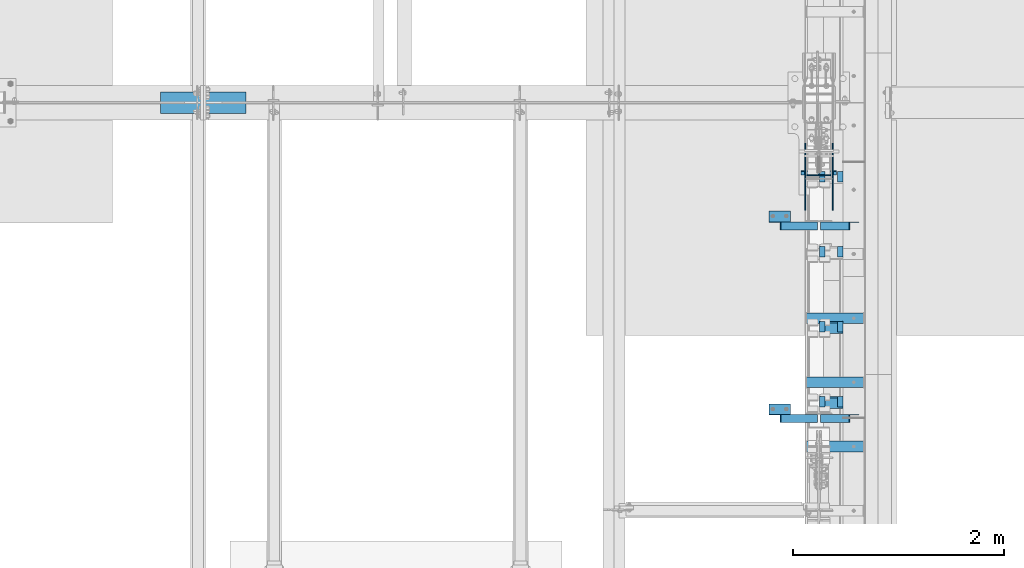
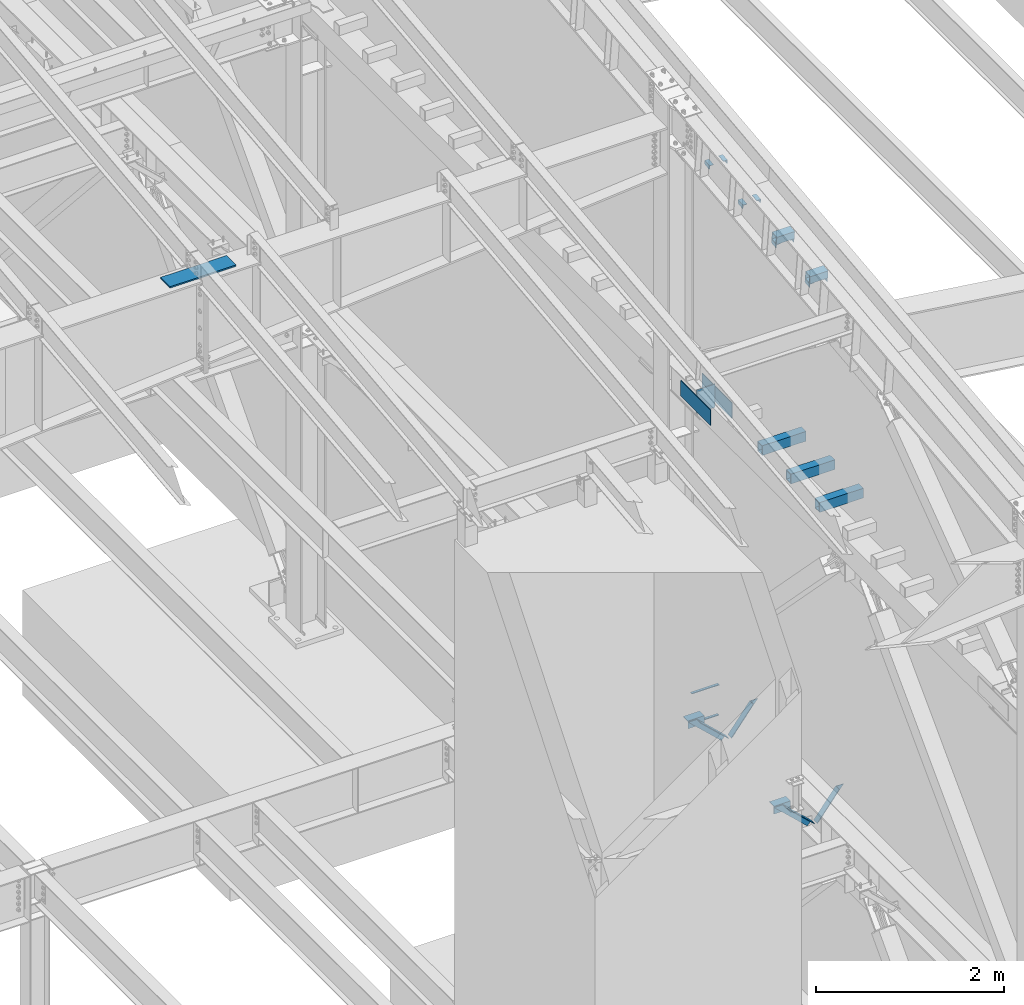
# One storey, part 837 of 1179: 21 beams, 4 members, 18 elements without a shape of their own.
"""IFC2X3 building model written with IfcOpenShell, lengths in millimetres."""

from ifc_helpers import new_model, si_unit, frame, origin_with_axes, place, context, subcontext, project, spatial, faceted_brep, material, type_object, element, aggregate, save


model = new_model("IFC2X3")

# Units and contexts
model_context = context("Model", 3, precision=1e-05, world=origin_with_axes())
body_context = subcontext(model_context, "Body", "Model", "MODEL_VIEW")
ifc_project = project(units=[si_unit("LENGTHUNIT", "METRE", prefix="MILLI"), si_unit("AREAUNIT", "SQUARE_METRE"), si_unit("VOLUMEUNIT", "CUBIC_METRE"), si_unit("MASSUNIT", "GRAM", prefix="KILO"), si_unit("TIMEUNIT", "SECOND"), si_unit("PLANEANGLEUNIT", "RADIAN"), si_unit("SOLIDANGLEUNIT", "STERADIAN"), si_unit("THERMODYNAMICTEMPERATUREUNIT", "DEGREE_CELSIUS"), si_unit("LUMINOUSINTENSITYUNIT", "LUMEN")], contexts=[model_context])

# Site, building, storey
site_placement = place(None, origin_with_axes())
site = spatial("IfcSite", under=ifc_project, at=site_placement, CompositionType="ELEMENT")
building_placement = place(site_placement, origin_with_axes())
building = spatial("IfcBuilding", under=site, at=building_placement, Name="Undefined", CompositionType="ELEMENT")
storey_placement = place(building_placement, origin_with_axes())
storey = spatial("IfcBuildingStorey", under=building, at=storey_placement, Name="Undefined", CompositionType="ELEMENT", Elevation=0.0)

# Assembly, member
assembly_1_placement = place(storey_placement, origin_with_axes())
assembly_1 = element("IfcElementAssembly", 1, at=assembly_1_placement, inside=storey, Name="ANGLE", AssemblyPlace="NOTDEFINED", PredefinedType="RIGID_FRAME")
ifc_material_1 = material(Name="STEEL/A36")
member_type = type_object("IfcMemberType", Name="L3X3X1/4", PredefinedType="NOTDEFINED")
member_1_placement = place(assembly_1_placement, frame((23812.1150890972, 18059.4, 4162.88757791506), z_axis=(0.0, -1.0, 0.0), x_axis=(0.729484494811633, 0.0, -0.683997347823379)))
member_1 = element("IfcMember", 2, at=member_1_placement, type_object=member_type, material=ifc_material_1, Name="ANGLE", ObjectType="L3X3X1/4", context=body_context, shape_type="Brep", body=[
    faceted_brep([(148.072119708857, 38.1000000000204, -38.0999999999985), (148.072119708857, 38.1000000000204, 38.0999999999985), (623.824460863128, 38.1000000000349, 38.0999999999985), (623.824460863128, 38.1000000000349, -38.0999999999985), (141.299832423247, 31.7500000000182, 38.0999999999985), (623.824460863128, 31.7500000000291, 38.0999999999985), (141.299832423247, 31.7500000000182, -31.75), (623.824460863128, 31.7500000000291, -31.75), (66.8046722815307, -38.1000000000095, -31.75), (623.824460863132, -38.0999999999913, -31.75), (66.8046722815307, -38.1000000000095, -38.0999999999985), (623.824460863132, -38.0999999999913, -38.0999999999985)], [[[0, 1, 2, 3]], [[1, 4, 5, 2]], [[4, 6, 7, 5]], [[6, 8, 9, 7]], [[8, 10, 11, 9]], [[10, 0, 3, 11]], [[5, 7, 9, 11, 3, 2]], [[10, 8, 6, 4, 1, 0]]]),
])
aggregate(assembly_1, [member_1])

assembly_2_placement = place(storey_placement, origin_with_axes())
assembly_2 = element("IfcElementAssembly", 3, at=assembly_2_placement, inside=storey, Name="ANGLE", AssemblyPlace="NOTDEFINED", PredefinedType="RIGID_FRAME")
member_2_placement = place(assembly_2_placement, frame((24352.3014298031, 18059.4, 3731.6636484264), z_axis=(0.0, -1.0, 0.0), x_axis=(0.614083067285056, 0.0, 0.789241399366365)))
member_2 = element("IfcMember", 4, at=member_2_placement, type_object=member_type, material=ifc_material_1, Name="ANGLE", ObjectType="L3X3X1/4", context=body_context, shape_type="Brep", body=[
    faceted_brep([(0.0, 38.0999999999985, -38.0999999999999), (0.0, 38.0999999999985, 38.0999999999999), (439.713105507173, 38.1000000000386, 38.0999999999985), (439.713105507173, 38.1000000000386, -38.0999999999985), (0.0, 31.75, 38.1000000000004), (444.653834009747, 31.7500000000473, 38.0999999999985), (0.0, 31.75, -31.75), (444.653834009747, 31.7500000000473, -31.75), (0.0, -38.0999999999985, -31.75), (499.001847538042, -38.0999999998749, -31.75), (0.0, -38.0999999999985, -38.0999999999999), (499.001847538042, -38.0999999998749, -38.0999999999985)], [[[0, 1, 2, 3]], [[1, 4, 5, 2]], [[4, 6, 7, 5]], [[6, 8, 9, 7]], [[8, 10, 11, 9]], [[10, 0, 3, 11]], [[5, 7, 9, 11, 3, 2]], [[10, 8, 6, 4, 1, 0]]]),
])
aggregate(assembly_2, [member_2])

assembly_3_placement = place(storey_placement, origin_with_axes())
assembly_3 = element("IfcElementAssembly", 5, at=assembly_3_placement, inside=storey, Name="ANGLE", AssemblyPlace="NOTDEFINED", PredefinedType="RIGID_FRAME")
member_3_placement = place(assembly_3_placement, frame((23812.1150890972, 16230.6, 4162.88757791506), z_axis=(0.0, -1.0, 0.0), x_axis=(0.729484494811633, 0.0, -0.683997347823379)))
member_3 = element("IfcMember", 6, at=member_3_placement, type_object=member_type, material=ifc_material_1, Name="ANGLE", ObjectType="L3X3X1/4", context=body_context, shape_type="Brep", body=[
    faceted_brep([(148.072119708857, 38.1000000000204, -38.0999999999985), (148.072119708857, 38.1000000000204, 38.0999999999985), (623.824460863128, 38.1000000000349, 38.0999999999985), (623.824460863128, 38.1000000000349, -38.0999999999985), (141.299832423247, 31.7500000000182, 38.0999999999985), (623.824460863128, 31.7500000000291, 38.0999999999985), (141.299832423247, 31.7500000000182, -31.75), (623.824460863128, 31.7500000000291, -31.75), (66.8046722815307, -38.1000000000095, -31.75), (623.824460863132, -38.0999999999913, -31.75), (66.8046722815307, -38.1000000000095, -38.0999999999985), (623.824460863132, -38.0999999999913, -38.0999999999985)], [[[0, 1, 2, 3]], [[1, 4, 5, 2]], [[4, 6, 7, 5]], [[6, 8, 9, 7]], [[8, 10, 11, 9]], [[10, 0, 3, 11]], [[5, 7, 9, 11, 3, 2]], [[10, 8, 6, 4, 1, 0]]]),
])
aggregate(assembly_3, [member_3])

assembly_4_placement = place(storey_placement, origin_with_axes())
assembly_4 = element("IfcElementAssembly", 7, at=assembly_4_placement, inside=storey, Name="ANGLE", AssemblyPlace="NOTDEFINED", PredefinedType="RIGID_FRAME")
member_4_placement = place(assembly_4_placement, frame((24352.3014298031, 16230.6, 3731.6636484264), z_axis=(0.0, -1.0, 0.0), x_axis=(0.614083067285056, 0.0, 0.789241399366365)))
member_4 = element("IfcMember", 8, at=member_4_placement, type_object=member_type, material=ifc_material_1, Name="ANGLE", ObjectType="L3X3X1/4", context=body_context, shape_type="Brep", body=[
    faceted_brep([(0.0, 38.0999999999985, -38.0999999999999), (0.0, 38.0999999999985, 38.0999999999999), (439.713105507173, 38.1000000000386, 38.0999999999985), (439.713105507173, 38.1000000000386, -38.0999999999985), (0.0, 31.75, 38.1000000000004), (444.653834009747, 31.7500000000473, 38.0999999999985), (0.0, 31.75, -31.75), (444.653834009747, 31.7500000000473, -31.75), (0.0, -38.0999999999985, -31.75), (499.001847538042, -38.0999999998749, -31.75), (0.0, -38.0999999999985, -38.0999999999999), (499.001847538042, -38.0999999998749, -38.0999999999985)], [[[0, 1, 2, 3]], [[1, 4, 5, 2]], [[4, 6, 7, 5]], [[6, 8, 9, 7]], [[8, 10, 11, 9]], [[10, 0, 3, 11]], [[5, 7, 9, 11, 3, 2]], [[10, 8, 6, 4, 1, 0]]]),
])
aggregate(assembly_4, [member_4])

# Assembly, beams
assembly_5_placement = place(storey_placement, origin_with_axes())
assembly_5 = element("IfcElementAssembly", 9, at=assembly_5_placement, inside=storey, Name="BEAM", AssemblyPlace="NOTDEFINED", PredefinedType="RIGID_FRAME")
ifc_material_2 = material(Name="STEEL/A572-GR.50")
beam_type_1 = type_object("IfcBeamType", PredefinedType="NOTDEFINED")
beam_1_placement = place(assembly_5_placement, frame((24307.8000366209, 18586.1140696771, 3678.2375), z_axis=(-1.0, 0.0, 0.0), x_axis=(0.0, -1.0, 0.0)))
beam_1 = element("IfcBeam", 10, at=beam_1_placement, type_object=beam_type_1, material=ifc_material_2, Name="PLATE", context=body_context, shape_type="Brep", body=[
    faceted_brep([(0.0, 4.76249999999982, -168.275000000001), (0.0, 4.76250000000073, 168.275), (31.75, 4.76249999999982, 168.275000000001), (31.75, 4.76249999999982, -168.275000000001), (0.0, -4.76250000000073, 168.275), (31.75, -4.76249999999982, 168.275000000001), (0.0, -4.76249999999982, -168.275000000001), (31.75, -4.76249999999982, -168.275000000001)], [[[0, 1, 2, 3]], [[1, 4, 5, 2]], [[4, 6, 7, 5]], [[6, 0, 3, 7]], [[5, 7, 3, 2]], [[6, 4, 1, 0]]]),
])
beam_2_placement = place(assembly_5_placement, frame((24307.8000366209, 18575.0015696771, 4077.8905), z_axis=(-1.0, 0.0, 0.0), x_axis=(0.0, -1.0, 0.0)))
beam_2 = element("IfcBeam", 11, at=beam_2_placement, type_object=beam_type_1, material=ifc_material_2, Name="PLATE", context=body_context, shape_type="Brep", body=[
    faceted_brep([(0.0, 4.76249999999982, -168.275000000001), (0.0, 4.76250000000073, 168.275), (31.75, 4.76249999999982, 168.275000000001), (31.75, 4.76249999999982, -168.275000000001), (0.0, -4.76250000000073, 168.275), (31.75, -4.76249999999982, 168.275000000001), (0.0, -4.76249999999982, -168.275000000001), (31.75, -4.76249999999982, -168.275000000001)], [[[0, 1, 2, 3]], [[1, 4, 5, 2]], [[4, 6, 7, 5]], [[6, 0, 3, 7]], [[5, 7, 3, 2]], [[6, 4, 1, 0]]]),
])
aggregate(assembly_5, [beam_1, beam_2])

# Assembly, beam
assembly_6_placement = place(storey_placement, origin_with_axes())
assembly_6 = element("IfcElementAssembly", 12, at=assembly_6_placement, inside=storey, Name="BEAM", AssemblyPlace="NOTDEFINED", PredefinedType="RIGID_FRAME")
beam_type_2 = type_object("IfcBeamType", Name="L2X2X1/4", PredefinedType="NOTDEFINED")
beam_3_placement = place(assembly_6_placement, frame((24511.0, 18475.6429543655, 10899.1275416578), z_axis=(0.0, 0.112284087038014, -0.993676146336441), x_axis=(0.0, 0.993676146336441, 0.112284087038017)))
beam_3 = element("IfcBeam", 13, at=beam_3_placement, type_object=beam_type_2, material=ifc_material_1, Name="ANGLE", ObjectType="L2X2X1/4", context=body_context, shape_type="Brep", body=[
    faceted_brep([(0.0, 25.3999999999996, -25.4000000000015), (0.0, 25.3999999999996, 25.4000000000015), (101.599999999555, 25.4, 25.3999999999451), (101.599999999537, 25.4, -25.4000000000251), (7.27595761418343e-12, 19.05, 25.3999999999851), (101.599999999555, 19.05, 25.3999999999451), (0.0, 19.0499992350015, -19.0499992349996), (101.600003324515, 19.0499992350051, -19.0499992350015), (-1.09139364212751e-11, -25.4, -19.0499999999865), (101.59999999954, -25.4, -19.0500000000302), (0.0, -25.3999999999996, -25.4000000000015), (101.599999999537, -25.4, -25.4000000000251)], [[[0, 1, 2, 3]], [[1, 4, 5, 2]], [[4, 6, 7, 5]], [[6, 8, 9, 7]], [[8, 10, 11, 9]], [[10, 0, 3, 11]], [[5, 7, 9, 11, 3, 2]], [[10, 8, 6, 4, 1, 0]]]),
])

assembly_7_placement = place(storey_placement, origin_with_axes())
assembly_7 = element("IfcElementAssembly", 14, at=assembly_7_placement, inside=storey, Name="BEAM", AssemblyPlace="NOTDEFINED", PredefinedType="RIGID_FRAME")
beam_4_placement = place(assembly_7_placement, frame((24340.34375, 18475.6429543655, 10899.1275416578), z_axis=(1.0, 0.0, 0.0), x_axis=(0.0, 0.993676146336441, 0.112284087038017)))
beam_4 = element("IfcBeam", 15, at=beam_4_placement, type_object=beam_type_2, material=ifc_material_1, Name="ANGLE", ObjectType="L2X2X1/4", context=body_context, shape_type="Brep", body=[
    faceted_brep([(0.0, 25.3999999999996, -25.4000000000015), (0.0, 25.3999999999996, 25.4000000000015), (101.599999999555, 25.4, 25.3999999999451), (101.599999999537, 25.4, -25.4000000000251), (7.27595761418343e-12, 19.05, 25.3999999999851), (101.599999999555, 19.05, 25.3999999999451), (0.0, 19.0499992350015, -19.0499992349996), (101.600003324515, 19.0499992350051, -19.0499992350015), (-1.09139364212751e-11, -25.4, -19.0499999999865), (101.59999999954, -25.4, -19.0500000000302), (0.0, -25.3999999999996, -25.4000000000015), (101.599999999537, -25.4, -25.4000000000251)], [[[0, 1, 2, 3]], [[1, 4, 5, 2]], [[4, 6, 7, 5]], [[6, 8, 9, 7]], [[8, 10, 11, 9]], [[10, 0, 3, 11]], [[5, 7, 9, 11, 3, 2]], [[10, 8, 6, 4, 1, 0]]]),
])

# Beam
beam_5_placement = place(assembly_6_placement, frame((24511.0, 17764.0119919854, 10818.6588636447), z_axis=(0.0, 0.112284087038014, -0.993676146336441), x_axis=(0.0, 0.993676146336441, 0.112284087038017)))
beam_5 = element("IfcBeam", 16, at=beam_5_placement, type_object=beam_type_2, material=ifc_material_1, Name="ANGLE", ObjectType="L2X2X1/4", context=body_context, shape_type="Brep", body=[
    faceted_brep([(0.0, 25.3999999999996, -25.4000000000015), (0.0, 25.3999999999996, 25.4000000000015), (101.599999999555, 25.4, 25.3999999999451), (101.599999999537, 25.4, -25.4000000000251), (7.27595761418343e-12, 19.05, 25.3999999999851), (101.599999999555, 19.05, 25.3999999999451), (0.0, 19.0499992350015, -19.0499992349996), (101.600003324515, 19.0499992350051, -19.0499992350015), (-1.09139364212751e-11, -25.4, -19.0499999999865), (101.59999999954, -25.4, -19.0500000000302), (0.0, -25.3999999999996, -25.4000000000015), (101.599999999537, -25.4, -25.4000000000251)], [[[0, 1, 2, 3]], [[1, 4, 5, 2]], [[4, 6, 7, 5]], [[6, 8, 9, 7]], [[8, 10, 11, 9]], [[10, 0, 3, 11]], [[5, 7, 9, 11, 3, 2]], [[10, 8, 6, 4, 1, 0]]]),
])

beam_6_placement = place(assembly_7_placement, frame((24340.34375, 17764.0119919854, 10818.6588636447), z_axis=(1.0, 0.0, 0.0), x_axis=(0.0, 0.993676146336441, 0.112284087038017)))
beam_6 = element("IfcBeam", 17, at=beam_6_placement, type_object=beam_type_2, material=ifc_material_1, Name="ANGLE", ObjectType="L2X2X1/4", context=body_context, shape_type="Brep", body=[
    faceted_brep([(0.0, 25.3999999999996, -25.4000000000015), (0.0, 25.3999999999996, 25.4000000000015), (101.599999999555, 25.4, 25.3999999999451), (101.599999999537, 25.4, -25.4000000000251), (7.27595761418343e-12, 19.05, 25.3999999999851), (101.599999999555, 19.05, 25.3999999999451), (0.0, 19.0499992350015, -19.0499992349996), (101.600003324515, 19.0499992350051, -19.0499992350015), (-1.09139364212751e-11, -25.4, -19.0499999999865), (101.59999999954, -25.4, -19.0500000000302), (0.0, -25.3999999999996, -25.4000000000015), (101.599999999537, -25.4, -25.4000000000251)], [[[0, 1, 2, 3]], [[1, 4, 5, 2]], [[4, 6, 7, 5]], [[6, 8, 9, 7]], [[8, 10, 11, 9]], [[10, 0, 3, 11]], [[5, 7, 9, 11, 3, 2]], [[10, 8, 6, 4, 1, 0]]]),
])

beam_7_placement = place(assembly_6_placement, frame((24511.0, 17052.3810296053, 10738.1901856316), z_axis=(0.0, 0.112284087038014, -0.993676146336441), x_axis=(0.0, 0.993676146336441, 0.112284087038017)))
beam_7 = element("IfcBeam", 18, at=beam_7_placement, type_object=beam_type_2, material=ifc_material_1, Name="ANGLE", ObjectType="L2X2X1/4", context=body_context, shape_type="Brep", body=[
    faceted_brep([(0.0, 25.3999999999996, -25.4000000000015), (0.0, 25.3999999999996, 25.4000000000015), (101.599999999555, 25.4, 25.3999999999451), (101.599999999537, 25.4, -25.4000000000251), (7.27595761418343e-12, 19.05, 25.3999999999851), (101.599999999555, 19.05, 25.3999999999451), (0.0, 19.0499992350015, -19.0499992349996), (101.600003324515, 19.0499992350051, -19.0499992350015), (-1.09139364212751e-11, -25.4, -19.0499999999865), (101.59999999954, -25.4, -19.0500000000302), (0.0, -25.3999999999996, -25.4000000000015), (101.599999999537, -25.4, -25.4000000000251)], [[[0, 1, 2, 3]], [[1, 4, 5, 2]], [[4, 6, 7, 5]], [[6, 8, 9, 7]], [[8, 10, 11, 9]], [[10, 0, 3, 11]], [[5, 7, 9, 11, 3, 2]], [[10, 8, 6, 4, 1, 0]]]),
])

beam_8_placement = place(assembly_7_placement, frame((24340.34375, 17052.3810296052, 10738.1901856316), z_axis=(1.0, 0.0, 0.0), x_axis=(0.0, 0.993676146336441, 0.112284087038017)))
beam_8 = element("IfcBeam", 19, at=beam_8_placement, type_object=beam_type_2, material=ifc_material_1, Name="ANGLE", ObjectType="L2X2X1/4", context=body_context, shape_type="Brep", body=[
    faceted_brep([(0.0, 25.3999999999996, -25.4000000000015), (0.0, 25.3999999999996, 25.4000000000015), (101.599999999555, 25.4, 25.3999999999451), (101.599999999537, 25.4, -25.4000000000251), (7.27595761418343e-12, 19.05, 25.3999999999851), (101.599999999555, 19.05, 25.3999999999451), (0.0, 19.0499992350015, -19.0499992349996), (101.600003324515, 19.0499992350051, -19.0499992350015), (-1.09139364212751e-11, -25.4, -19.0499999999865), (101.59999999954, -25.4, -19.0500000000302), (0.0, -25.3999999999996, -25.4000000000015), (101.599999999537, -25.4, -25.4000000000251)], [[[0, 1, 2, 3]], [[1, 4, 5, 2]], [[4, 6, 7, 5]], [[6, 8, 9, 7]], [[8, 10, 11, 9]], [[10, 0, 3, 11]], [[5, 7, 9, 11, 3, 2]], [[10, 8, 6, 4, 1, 0]]]),
])

beam_9_placement = place(assembly_6_placement, frame((24511.0, 16340.7500672251, 10657.7215076184), z_axis=(0.0, 0.112284087038014, -0.993676146336441), x_axis=(0.0, 0.993676146336441, 0.112284087038017)))
beam_9 = element("IfcBeam", 20, at=beam_9_placement, type_object=beam_type_2, material=ifc_material_1, Name="ANGLE", ObjectType="L2X2X1/4", context=body_context, shape_type="Brep", body=[
    faceted_brep([(0.0, 25.3999999999996, -25.4000000000015), (0.0, 25.3999999999996, 25.4000000000015), (101.599999999555, 25.4, 25.3999999999451), (101.599999999537, 25.4, -25.4000000000251), (7.27595761418343e-12, 19.05, 25.3999999999851), (101.599999999555, 19.05, 25.3999999999451), (0.0, 19.0499992350015, -19.0499992349996), (101.600003324515, 19.0499992350051, -19.0499992350015), (-1.09139364212751e-11, -25.4, -19.0499999999865), (101.59999999954, -25.4, -19.0500000000302), (0.0, -25.3999999999996, -25.4000000000015), (101.599999999537, -25.4, -25.4000000000251)], [[[0, 1, 2, 3]], [[1, 4, 5, 2]], [[4, 6, 7, 5]], [[6, 8, 9, 7]], [[8, 10, 11, 9]], [[10, 0, 3, 11]], [[5, 7, 9, 11, 3, 2]], [[10, 8, 6, 4, 1, 0]]]),
])

aggregate(assembly_6, [beam_3, beam_5, beam_7, beam_9])

beam_10_placement = place(assembly_7_placement, frame((24340.34375, 16340.7500672251, 10657.7215076184), z_axis=(1.0, 0.0, 0.0), x_axis=(0.0, 0.993676146336441, 0.112284087038017)))
beam_10 = element("IfcBeam", 21, at=beam_10_placement, type_object=beam_type_2, material=ifc_material_1, Name="ANGLE", ObjectType="L2X2X1/4", context=body_context, shape_type="Brep", body=[
    faceted_brep([(0.0, 25.3999999999996, -25.4000000000015), (0.0, 25.3999999999996, 25.4000000000015), (101.599999999555, 25.4, 25.3999999999451), (101.599999999537, 25.4, -25.4000000000251), (7.27595761418343e-12, 19.05, 25.3999999999851), (101.599999999555, 19.05, 25.3999999999451), (0.0, 19.0499992350015, -19.0499992349996), (101.600003324515, 19.0499992350051, -19.0499992350015), (-1.09139364212751e-11, -25.4, -19.0499999999865), (101.59999999954, -25.4, -19.0500000000302), (0.0, -25.3999999999996, -25.4000000000015), (101.599999999537, -25.4, -25.4000000000251)], [[[0, 1, 2, 3]], [[1, 4, 5, 2]], [[4, 6, 7, 5]], [[6, 8, 9, 7]], [[8, 10, 11, 9]], [[10, 0, 3, 11]], [[5, 7, 9, 11, 3, 2]], [[10, 8, 6, 4, 1, 0]]]),
])

aggregate(assembly_7, [beam_4, beam_6, beam_8, beam_10])

# Assembly, beam
assembly_8_placement = place(storey_placement, origin_with_axes())
assembly_8 = element("IfcElementAssembly", 22, at=assembly_8_placement, inside=storey, Name="RAFTER BEAM", AssemblyPlace="NOTDEFINED", PredefinedType="RIGID_FRAME")
beam_type_3 = type_object("IfcBeamType", PredefinedType="NOTDEFINED")
beam_11_placement = place(assembly_8_placement, frame((18059.4, 19227.8, 11137.10625), z_axis=(0.0, -1.0, 0.0), x_axis=(1.0, 0.0, 0.0)))
beam_11 = element("IfcBeam", 23, at=beam_11_placement, type_object=beam_type_3, material=ifc_material_2, Name="PLATE", context=body_context, shape_type="Brep", body=[
    faceted_brep([(0.0, 9.52500000000009, -101.599999999999), (0.0, 9.52500000000009, 101.599999999999), (812.799999999999, 9.52499999999964, 101.6), (812.799999999999, 9.52499999999964, -101.6), (0.0, -9.52500000000009, 101.599999999999), (812.799999999999, -9.52499999999964, 101.6), (0.0, -9.52500000000009, -101.599999999999), (812.799999999999, -9.52499999999964, -101.6)], [[[0, 1, 2, 3]], [[1, 4, 5, 2]], [[4, 6, 7, 5]], [[6, 0, 3, 7]], [[5, 7, 3, 2]], [[6, 4, 1, 0]]]),
])
aggregate(assembly_8, [beam_11])

assembly_9_placement = place(storey_placement, origin_with_axes())
assembly_9 = element("IfcElementAssembly", 24, at=assembly_9_placement, inside=storey, Name="ANGLE", AssemblyPlace="NOTDEFINED", PredefinedType="RIGID_FRAME")
beam_type_4 = type_object("IfcBeamType", Name="L4X4X1/4", PredefinedType="NOTDEFINED")
beam_12_placement = place(assembly_9_placement, frame((23834.8036446584, 18148.3, 4051.3), z_axis=(0.0, 0.0, -1.0), x_axis=(1.0, 0.0, 0.0)))
beam_12 = element("IfcBeam", 25, at=beam_12_placement, type_object=beam_type_4, material=ifc_material_1, Name="ANGLE", ObjectType="L4X4X1/4", context=body_context, shape_type="Brep", body=[
    faceted_brep([(1.90993887372315e-11, 50.8000000000002, -50.8000000000002), (1.90993887372315e-11, 50.8000000000002, 50.8000000000002), (203.200000000001, 50.7999999999993, 50.8000000000002), (203.200000000001, 50.7999999999993, -50.8000000000002), (0.0, 44.4500000000007, 50.8000000000002), (203.200000000001, 44.4500000000007, 50.8000000000002), (0.0, 44.4500000000007, -44.4499999999998), (203.200000000001, 44.4500000000007, -44.4499999999998), (0.0, -50.7999999999993, -44.4499999999998), (203.200000000001, -50.7999999999993, -44.4499999999998), (-1.81898940354586e-11, -50.7999999999997, -50.8000000000002), (203.200000000001, -50.7999999999993, -50.8000000000002)], [[[0, 1, 2, 3]], [[1, 4, 5, 2]], [[4, 6, 7, 5]], [[6, 8, 9, 7]], [[8, 10, 11, 9]], [[10, 0, 3, 11]], [[5, 7, 9, 11, 3, 2]], [[10, 8, 6, 4, 1, 0]]]),
])
aggregate(assembly_9, [beam_12])

assembly_10_placement = place(storey_placement, origin_with_axes())
assembly_10 = element("IfcElementAssembly", 26, at=assembly_10_placement, inside=storey, Name="ANGLE", AssemblyPlace="NOTDEFINED", PredefinedType="RIGID_FRAME")
beam_13_placement = place(assembly_10_placement, frame((23834.8036446584, 16319.5, 4051.3), z_axis=(0.0, 0.0, -1.0), x_axis=(1.0, 0.0, 0.0)))
beam_13 = element("IfcBeam", 27, at=beam_13_placement, type_object=beam_type_4, material=ifc_material_1, Name="ANGLE", ObjectType="L4X4X1/4", context=body_context, shape_type="Brep", body=[
    faceted_brep([(1.90993887372315e-11, 50.8000000000002, -50.8000000000002), (1.90993887372315e-11, 50.8000000000002, 50.8000000000002), (203.200000000001, 50.7999999999993, 50.8000000000002), (203.200000000001, 50.7999999999993, -50.8000000000002), (0.0, 44.4500000000007, 50.8000000000002), (203.200000000001, 44.4500000000007, 50.8000000000002), (0.0, 44.4500000000007, -44.4499999999998), (203.200000000001, 44.4500000000007, -44.4499999999998), (0.0, -50.7999999999993, -44.4499999999998), (203.200000000001, -50.7999999999993, -44.4499999999998), (-1.81898940354586e-11, -50.7999999999997, -50.8000000000002), (203.200000000001, -50.7999999999993, -50.8000000000002)], [[[0, 1, 2, 3]], [[1, 4, 5, 2]], [[4, 6, 7, 5]], [[6, 8, 9, 7]], [[8, 10, 11, 9]], [[10, 0, 3, 11]], [[5, 7, 9, 11, 3, 2]], [[10, 8, 6, 4, 1, 0]]]),
])
aggregate(assembly_10, [beam_13])

assembly_11_placement = place(storey_placement, origin_with_axes())
assembly_11 = element("IfcElementAssembly", 28, at=assembly_11_placement, inside=storey, Name="PLATE", AssemblyPlace="NOTDEFINED", PredefinedType="RIGID_FRAME")
beam_type_5 = type_object("IfcBeamType", PredefinedType="NOTDEFINED")
beam_14_placement = place(assembly_11_placement, frame((24439.5625, 18840.6248035139, 7861.3), z_axis=(0.0, 0.0, 1.0), x_axis=(0.0, -1.0, 0.0)))
beam_14 = element("IfcBeam", 29, at=beam_14_placement, type_object=beam_type_5, material=ifc_material_2, Name="PLATE", context=body_context, shape_type="Brep", body=[
    faceted_brep([(0.0, 4.76250000000073, -101.6), (0.0, 4.76250000000073, 101.6), (635.0, 4.76250000000073, 101.6), (635.0, 4.76250000000073, -101.6), (0.0, -4.76250000000073, 101.6), (635.0, -4.76250000000073, 101.6), (0.0, -4.76250000000073, -101.6), (635.0, -4.76250000000073, -101.6)], [[[0, 1, 2, 3]], [[1, 4, 5, 2]], [[4, 6, 7, 5]], [[6, 0, 3, 7]], [[5, 7, 3, 2]], [[6, 4, 1, 0]]]),
])
aggregate(assembly_11, [beam_14])

assembly_12_placement = place(storey_placement, origin_with_axes())
assembly_12 = element("IfcElementAssembly", 30, at=assembly_12_placement, inside=storey, Name="PLATE", AssemblyPlace="NOTDEFINED", PredefinedType="RIGID_FRAME")
beam_15_placement = place(assembly_12_placement, frame((24176.0375, 18840.6248035139, 7861.3), z_axis=(0.0, 0.0, 1.0), x_axis=(0.0, -1.0, 0.0)))
beam_15 = element("IfcBeam", 31, at=beam_15_placement, type_object=beam_type_5, material=ifc_material_2, Name="PLATE", context=body_context, shape_type="Brep", body=[
    faceted_brep([(0.0, 4.76250000000073, -101.6), (0.0, 4.76250000000073, 101.6), (635.0, 4.76250000000073, 101.6), (635.0, 4.76250000000073, -101.6), (0.0, -4.76250000000073, 101.6), (635.0, -4.76250000000073, 101.6), (0.0, -4.76250000000073, -101.6), (635.0, -4.76250000000073, -101.6)], [[[0, 1, 2, 3]], [[1, 4, 5, 2]], [[4, 6, 7, 5]], [[6, 0, 3, 7]], [[5, 7, 3, 2]], [[6, 4, 1, 0]]]),
])
aggregate(assembly_12, [beam_15])

assembly_13_placement = place(storey_placement, origin_with_axes())
assembly_13 = element("IfcElementAssembly", 32, at=assembly_13_placement, inside=storey, Name="COLUMN", AssemblyPlace="NOTDEFINED", PredefinedType="RIGID_FRAME")
beam_type_6 = type_object("IfcBeamType", PredefinedType="NOTDEFINED")
beam_16_placement = place(assembly_13_placement, frame((24193.5, 18540.5873035139, 7861.3), z_axis=(0.0, 0.0, 1.0), x_axis=(1.0, 0.0, 0.0)))
beam_16 = element("IfcBeam", 33, at=beam_16_placement, type_object=beam_type_6, material=ifc_material_2, Name="PLATE", context=body_context, shape_type="Brep", body=[
    faceted_brep([(0.0, 4.76250000000073, -152.4), (0.0, 4.76250000000073, 152.4), (228.600000000002, 4.76250000000073, 152.4), (228.600000000002, 4.76250000000073, -152.4), (0.0, -4.76250000000073, 152.4), (228.600000000002, -4.76250000000073, 152.4), (0.0, -4.76250000000073, -152.4), (228.600000000002, -4.76250000000073, -152.4)], [[[0, 1, 2, 3]], [[1, 4, 5, 2]], [[4, 6, 7, 5]], [[6, 0, 3, 7]], [[5, 7, 3, 2]], [[6, 4, 1, 0]]]),
])
aggregate(assembly_13, [beam_16])

assembly_14_placement = place(storey_placement, origin_with_axes())
assembly_14 = element("IfcElementAssembly", 34, at=assembly_14_placement, inside=storey, Name="BEAM", AssemblyPlace="NOTDEFINED", PredefinedType="RIGID_FRAME")
ifc_material_3 = material()
beam_type_7 = type_object("IfcBeamType", Name="HSS4X4X5/16", PredefinedType="NOTDEFINED")
beam_17_placement = place(assembly_14_placement, frame((24307.8, 17094.3037304068, 10819.6123396039), z_axis=(0.0, -0.112284087038017, 0.993676146336441), x_axis=(1.0, 0.0, 0.0)))
beam_17 = element("IfcBeam", 35, at=beam_17_placement, type_object=beam_type_7, material=ifc_material_3, Name="BEAM", ObjectType="HSS4X4X5/16", context=body_context, shape_type="Brep", body=[
    faceted_brep([(7.14374999999757, 42.8624999999884, -42.8624999999574), (7.14374999999757, -42.8624999999593, -42.862499999992), (228.600000000002, -42.8624999999593, -42.862499999992), (228.600000000002, 42.8624999999884, -42.8624999999574), (7.14374999999757, -42.8624999999956, 42.8624999999611), (228.600000000002, -42.8624999999956, 42.8624999999611), (7.14374999999757, 42.862499999952, 42.8624999999938), (228.600000000002, 42.862499999952, 42.8624999999938), (7.14374999999757, 50.7999999999884, -50.7999999999502), (7.14374999999757, 50.7999999999447, 50.7999999999938), (228.600000000002, 50.7999999999447, 50.7999999999938), (228.600000000002, 50.7999999999884, -50.7999999999502), (7.14374999999757, -50.7999999999956, 50.799999999952), (228.600000000002, -50.7999999999956, 50.799999999952), (7.14374999999757, -50.7999999999556, -50.7999999999902), (228.600000000002, -50.7999999999556, -50.7999999999902)], [[[0, 1, 2, 3]], [[1, 4, 5, 2]], [[4, 6, 7, 5]], [[6, 0, 3, 7]], [[8, 9, 10, 11]], [[9, 12, 13, 10]], [[12, 14, 15, 13]], [[14, 8, 11, 15]], [[13, 15, 11, 10], [5, 7, 3, 2]], [[14, 12, 9, 8], [6, 4, 1, 0]]]),
])
aggregate(assembly_14, [beam_17])

assembly_15_placement = place(storey_placement, origin_with_axes())
assembly_15 = element("IfcElementAssembly", 36, at=assembly_15_placement, inside=storey, Name="BEAM", AssemblyPlace="NOTDEFINED", PredefinedType="RIGID_FRAME")
beam_18_placement = place(assembly_15_placement, frame((24307.8, 16382.6727680267, 10739.1436615907), z_axis=(0.0, -0.112284087038017, 0.993676146336441), x_axis=(1.0, 0.0, 0.0)))
beam_18 = element("IfcBeam", 37, at=beam_18_placement, type_object=beam_type_7, material=ifc_material_3, Name="BEAM", ObjectType="HSS4X4X5/16", context=body_context, shape_type="Brep", body=[
    faceted_brep([(7.14374999999757, 42.8624999999884, -42.8624999999574), (7.14374999999757, -42.8624999999593, -42.862499999992), (228.600000000002, -42.8624999999593, -42.862499999992), (228.600000000002, 42.8624999999884, -42.8624999999574), (7.14374999999757, -42.8624999999956, 42.8624999999611), (228.600000000002, -42.8624999999956, 42.8624999999611), (7.14374999999757, 42.862499999952, 42.8624999999938), (228.600000000002, 42.862499999952, 42.8624999999938), (7.14374999999757, 50.7999999999884, -50.7999999999502), (7.14374999999757, 50.7999999999447, 50.7999999999938), (228.600000000002, 50.7999999999447, 50.7999999999938), (228.600000000002, 50.7999999999884, -50.7999999999502), (7.14374999999757, -50.7999999999956, 50.799999999952), (228.600000000002, -50.7999999999956, 50.799999999952), (7.14374999999757, -50.7999999999556, -50.7999999999902), (228.600000000002, -50.7999999999556, -50.7999999999902)], [[[0, 1, 2, 3]], [[1, 4, 5, 2]], [[4, 6, 7, 5]], [[6, 0, 3, 7]], [[8, 9, 10, 11]], [[9, 12, 13, 10]], [[12, 14, 15, 13]], [[14, 8, 11, 15]], [[13, 15, 11, 10], [5, 7, 3, 2]], [[14, 12, 9, 8], [6, 4, 1, 0]]]),
])
aggregate(assembly_15, [beam_18])

assembly_16_placement = place(storey_placement, origin_with_axes())
assembly_16 = element("IfcElementAssembly", 38, at=assembly_16_placement, inside=storey, Name="BEAM", AssemblyPlace="NOTDEFINED", PredefinedType="RIGID_FRAME")
beam_type_8 = type_object("IfcBeamType", Name="HSS5X4X3/8", PredefinedType="NOTDEFINED")
beam_19_placement = place(assembly_16_placement, frame((24180.8, 17183.1, 8077.19999998781), z_axis=(0.0, 0.0, 1.0), x_axis=(1.0, 0.0, 0.0)))
beam_19 = element("IfcBeam", 39, at=beam_19_placement, type_object=beam_type_8, material=ifc_material_3, Name="BEAM", ObjectType="HSS5X4X3/8", context=body_context, shape_type="Brep", body=[
    faceted_brep([(9.52500000000146, 41.2750000000015, -53.9750000000004), (9.52500000000146, -41.2750000000015, -53.9750000000004), (549.274999999994, -41.2750000000015, -53.9750000000004), (549.274999999994, 41.2750000000015, -53.9750000000004), (9.52500000000146, -41.2750000000015, 53.9750000000004), (549.274999999994, -41.2750000000015, 53.9750000000004), (9.52500000000146, 41.2750000000015, 53.9750000000004), (549.274999999994, 41.2750000000015, 53.9750000000004), (9.52500000000146, 50.7999999999993, -63.5), (9.52500000000146, 50.7999999999993, 63.5), (549.274999999994, 50.7999999999993, 63.5), (549.274999999994, 50.7999999999993, -63.5), (9.52500000000146, -50.7999999999993, 63.5), (549.274999999994, -50.7999999999993, 63.5), (9.52500000000146, -50.7999999999993, -63.5), (549.274999999994, -50.7999999999993, -63.5)], [[[0, 1, 2, 3]], [[1, 4, 5, 2]], [[4, 6, 7, 5]], [[6, 0, 3, 7]], [[8, 9, 10, 11]], [[9, 12, 13, 10]], [[12, 14, 15, 13]], [[14, 8, 11, 15]], [[13, 15, 11, 10], [5, 7, 3, 2]], [[14, 12, 9, 8], [6, 4, 1, 0]]]),
])
aggregate(assembly_16, [beam_19])

assembly_17_placement = place(storey_placement, origin_with_axes())
assembly_17 = element("IfcElementAssembly", 40, at=assembly_17_placement, inside=storey, Name="BEAM", AssemblyPlace="NOTDEFINED", PredefinedType="RIGID_FRAME")
beam_20_placement = place(assembly_17_placement, frame((24180.8, 16573.5, 8077.19999998781), z_axis=(0.0, 0.0, 1.0), x_axis=(1.0, 0.0, 0.0)))
beam_20 = element("IfcBeam", 41, at=beam_20_placement, type_object=beam_type_8, material=ifc_material_3, Name="BEAM", ObjectType="HSS5X4X3/8", context=body_context, shape_type="Brep", body=[
    faceted_brep([(9.52500000000146, 41.2750000000015, -53.9750000000004), (9.52500000000146, -41.2750000000015, -53.9750000000004), (549.274999999994, -41.2750000000015, -53.9750000000004), (549.274999999994, 41.2750000000015, -53.9750000000004), (9.52500000000146, -41.2750000000015, 53.9750000000004), (549.274999999994, -41.2750000000015, 53.9750000000004), (9.52500000000146, 41.2750000000015, 53.9750000000004), (549.274999999994, 41.2750000000015, 53.9750000000004), (9.52500000000146, 50.7999999999993, -63.5), (9.52500000000146, 50.7999999999993, 63.5), (549.274999999994, 50.7999999999993, 63.5), (549.274999999994, 50.7999999999993, -63.5), (9.52500000000146, -50.7999999999993, 63.5), (549.274999999994, -50.7999999999993, 63.5), (9.52500000000146, -50.7999999999993, -63.5), (549.274999999994, -50.7999999999993, -63.5)], [[[0, 1, 2, 3]], [[1, 4, 5, 2]], [[4, 6, 7, 5]], [[6, 0, 3, 7]], [[8, 9, 10, 11]], [[9, 12, 13, 10]], [[12, 14, 15, 13]], [[14, 8, 11, 15]], [[13, 15, 11, 10], [5, 7, 3, 2]], [[14, 12, 9, 8], [6, 4, 1, 0]]]),
])
aggregate(assembly_17, [beam_20])

assembly_18_placement = place(storey_placement, origin_with_axes())
assembly_18 = element("IfcElementAssembly", 42, at=assembly_18_placement, inside=storey, Name="BEAM", AssemblyPlace="NOTDEFINED", PredefinedType="RIGID_FRAME")
beam_21_placement = place(assembly_18_placement, frame((24180.8, 15963.9, 8077.19999998781), z_axis=(0.0, 0.0, 1.0), x_axis=(1.0, 0.0, 0.0)))
beam_21 = element("IfcBeam", 43, at=beam_21_placement, type_object=beam_type_8, material=ifc_material_3, Name="BEAM", ObjectType="HSS5X4X3/8", context=body_context, shape_type="Brep", body=[
    faceted_brep([(9.52500000000146, 41.2750000000015, -53.9750000000004), (9.52500000000146, -41.2750000000015, -53.9750000000004), (549.274999999994, -41.2750000000015, -53.9750000000004), (549.274999999994, 41.2750000000015, -53.9750000000004), (9.52500000000146, -41.2750000000015, 53.9750000000004), (549.274999999994, -41.2750000000015, 53.9750000000004), (9.52500000000146, 41.2750000000015, 53.9750000000004), (549.274999999994, 41.2750000000015, 53.9750000000004), (9.52500000000146, 50.7999999999993, -63.5), (9.52500000000146, 50.7999999999993, 63.5), (549.274999999994, 50.7999999999993, 63.5), (549.274999999994, 50.7999999999993, -63.5), (9.52500000000146, -50.7999999999993, 63.5), (549.274999999994, -50.7999999999993, 63.5), (9.52500000000146, -50.7999999999993, -63.5), (549.274999999994, -50.7999999999993, -63.5)], [[[0, 1, 2, 3]], [[1, 4, 5, 2]], [[4, 6, 7, 5]], [[6, 0, 3, 7]], [[8, 9, 10, 11]], [[9, 12, 13, 10]], [[12, 14, 15, 13]], [[14, 8, 11, 15]], [[13, 15, 11, 10], [5, 7, 3, 2]], [[14, 12, 9, 8], [6, 4, 1, 0]]]),
])
aggregate(assembly_18, [beam_21])

save(model, "model.ifc")
